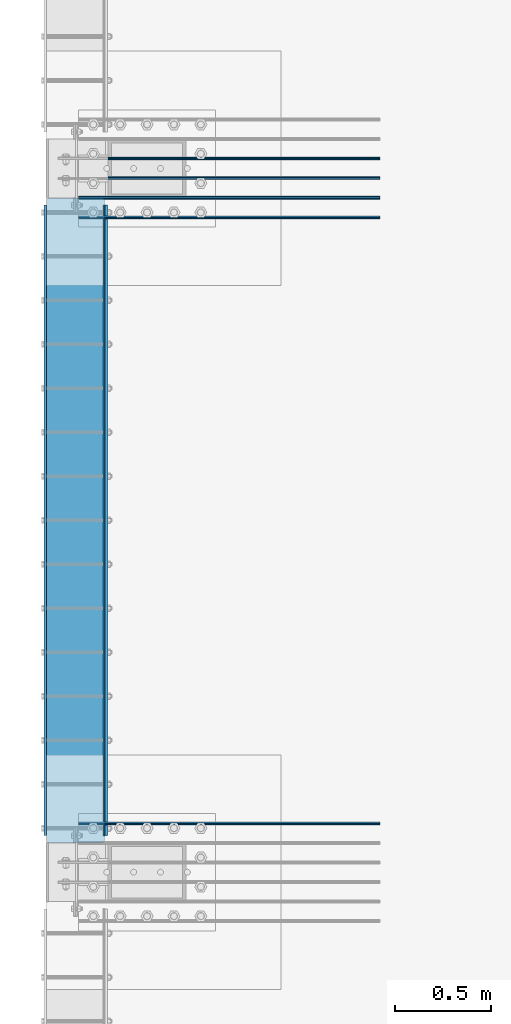
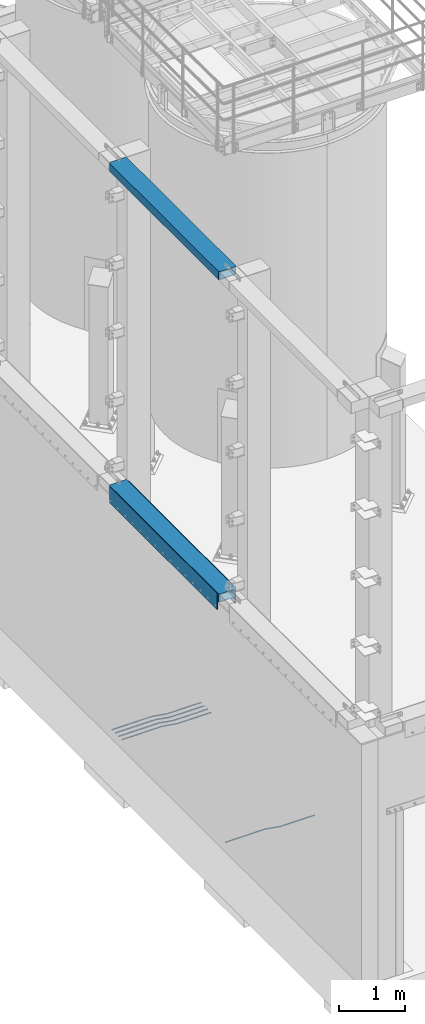
# One storey, part 911 of 1876: 10 beams, 5 elements without a shape of their own.
"""IFC2X3 building model written with IfcOpenShell, lengths in millimetres."""

from ifc_helpers import new_model, si_unit, frame, origin_with_axes, place, context, subcontext, project, spatial, faceted_brep, material, type_object, element, aggregate, save


model = new_model("IFC2X3")

# Units and contexts
model_context = context("Model", 3, precision=1e-05, world=origin_with_axes())
body_context = subcontext(model_context, "Body", "Model", "MODEL_VIEW")
ifc_project = project(units=[si_unit("LENGTHUNIT", "METRE", prefix="MILLI"), si_unit("AREAUNIT", "SQUARE_METRE"), si_unit("VOLUMEUNIT", "CUBIC_METRE"), si_unit("MASSUNIT", "GRAM", prefix="KILO"), si_unit("TIMEUNIT", "SECOND"), si_unit("PLANEANGLEUNIT", "RADIAN"), si_unit("SOLIDANGLEUNIT", "STERADIAN"), si_unit("THERMODYNAMICTEMPERATUREUNIT", "DEGREE_CELSIUS"), si_unit("LUMINOUSINTENSITYUNIT", "LUMEN")], contexts=[model_context])

# Site, building, storey
site_placement = place(None, origin_with_axes())
site = spatial("IfcSite", under=ifc_project, at=site_placement, CompositionType="ELEMENT")
building_placement = place(site_placement, origin_with_axes())
building = spatial("IfcBuilding", under=site, at=building_placement, Name="Undefined", CompositionType="ELEMENT")
storey_placement = place(building_placement, origin_with_axes())
storey = spatial("IfcBuildingStorey", under=building, at=storey_placement, Name="Undefined", CompositionType="ELEMENT", Elevation=0.0)

# Assembly, beam
assembly_1_placement = place(storey_placement, origin_with_axes())
assembly_1 = element("IfcElementAssembly", 1, at=assembly_1_placement, inside=storey, Name="BEAM", AssemblyPlace="NOTDEFINED", PredefinedType="RIGID_FRAME")
ifc_material_1 = material()
beam_type_1 = type_object("IfcBeamType", Name="HSS12X6X1/2", PredefinedType="NOTDEFINED")
beam_1_placement = place(assembly_1_placement, frame((-139.7, -21590.0, 10591.8), z_axis=(-1.0, 0.0, 0.0), x_axis=(0.0, 1.0, 0.0)))
beam_1 = element("IfcBeam", 2, at=beam_1_placement, type_object=beam_type_1, material=ifc_material_1, Name="BEAM", ObjectType="HSS12X6X1/2", context=body_context, shape_type="Brep", body=[
    faceted_brep([(0.0, -63.5, -139.7), (0.0, -76.2000000000007, -139.699999999812), (0.0, -76.2000000000007, 139.700000000026), (0.0, -63.5, 139.7), (0.0, 76.2000000000007, 139.700000000026), (0.0, 63.5, 139.7), (12.6999999999734, -76.2000000000007, 152.4), (12.6999999999734, 76.2000000000007, 152.4), (0.0, 76.2000000000007, -139.699999999812), (0.0, 63.5, -139.7), (12.7000000000025, -76.2000000000007, -152.4), (12.7000000000025, 76.2000000000007, -152.4), (3340.1, 76.2000000000007, -152.4), (3340.1, -76.2000000000007, -152.4), (3352.8, -63.5, -139.7), (3352.8, 63.5, -139.7), (3352.8, 76.2000000000007, -139.7), (3352.8, -76.2000000000007, -139.7), (3352.8, -76.2000000000007, 139.7), (3340.1, -76.2000000000007, 152.4), (3340.1, 76.2000000000007, 152.4), (3352.8, 76.2000000000007, 139.7), (3352.8, 63.5, 139.7), (3352.8, -63.5, 139.7)], [[[0, 1, 2, 3]], [[4, 5, 3, 2, 6, 7]], [[8, 9, 5, 4]], [[10, 11, 12, 13]], [[0, 9, 8, 11, 10, 1]], [[9, 0, 14, 15]], [[12, 16, 15, 14, 17, 13]], [[6, 2, 1, 10, 13, 17, 18, 19]], [[7, 6, 19, 20]], [[16, 12, 11, 8, 4, 7, 20, 21]], [[15, 16, 21, 22]], [[5, 9, 15, 22]], [[3, 5, 22, 23]], [[0, 3, 23, 14]], [[17, 14, 23, 18]], [[22, 21, 20, 19, 18, 23]]]),
])
aggregate(assembly_1, [beam_1])

assembly_2_placement = place(storey_placement, origin_with_axes())
assembly_2 = element("IfcElementAssembly", 3, at=assembly_2_placement, inside=storey, Name="BEAM", AssemblyPlace="NOTDEFINED", PredefinedType="RIGID_FRAME")
beam_2_placement = place(assembly_2_placement, frame((-139.7, -21590.0, 4597.4), z_axis=(-1.0, 0.0, 0.0), x_axis=(0.0, 1.0, 0.0)))
beam_2 = element("IfcBeam", 4, at=beam_2_placement, type_object=beam_type_1, material=ifc_material_1, Name="BEAM", ObjectType="HSS12X6X1/2", context=body_context, shape_type="Brep", body=[
    faceted_brep([(3340.10010842724, 76.1999999999998, -152.4), (3340.10010842724, -76.1999999999998, -152.4), (12.6998385541701, -76.2000000000007, -152.4), (12.6998385541701, 76.2000000000007, -152.4), (0.0, -63.5, -139.7), (0.0, 63.5, -139.7), (0.0, 76.2000000000007, -139.699999999812), (0.0, -76.2000000000007, -139.699999999812), (3352.8, -63.5, -139.7), (3352.8, 63.5, -139.7), (3352.8, 76.2000000000007, -139.7), (3352.8, -76.2000000000007, -139.7), (3352.8, -76.2000000000007, 139.7), (3340.1, -76.2000000000007, 152.4), (12.6999999999734, -76.2000000000007, 152.4), (0.0, -76.2000000000007, 139.700000000026), (0.0, -63.5, 139.7), (0.0, 63.5, 139.7), (3352.8, 63.5, 139.7), (3352.8, -63.5, 139.7), (3352.8, 76.2000000000007, 139.7), (3340.1, 76.2000000000007, 152.4), (0.0, 76.2000000000007, 139.700000000026), (12.6999999999734, 76.2000000000007, 152.4)], [[[0, 1, 2, 3]], [[4, 5, 6, 3, 2, 7]], [[5, 4, 8, 9]], [[0, 10, 9, 8, 11, 1]], [[7, 2, 1, 11, 12, 13, 14, 15]], [[4, 7, 15, 16]], [[16, 17, 18, 19]], [[4, 16, 19, 8]], [[11, 8, 19, 12]], [[18, 20, 21, 13, 12, 19]], [[9, 10, 20, 18]], [[17, 5, 9, 18]], [[6, 5, 17, 22]], [[21, 20, 10, 0, 3, 6, 22, 23]], [[23, 14, 13, 21]], [[22, 17, 16, 15, 14, 23]]]),
])

# Assembly, beams
assembly_3_placement = place(storey_placement, origin_with_axes())
assembly_3 = element("IfcElementAssembly", 5, at=assembly_3_placement, inside=storey, Name="PLATE", AssemblyPlace="NOTDEFINED", PredefinedType="RIGID_FRAME")
ifc_material_2 = material(Name="STEEL/A36")
beam_type_2 = type_object("IfcBeamType", PredefinedType="NOTDEFINED")
beam_3_placement = place(assembly_3_placement, frame((8.73150000000262, -18275.3, 4432.3), z_axis=(0.0, 0.0, 1.0), x_axis=(0.0, -1.0, 0.0)))
beam_3 = element("IfcBeam", 6, at=beam_3_placement, type_object=beam_type_2, material=ifc_material_2, Name="PLATE", context=body_context, shape_type="Brep", body=[
    faceted_brep([(0.0, 3.969, -38.1000000000004), (0.0, 3.969, 38.1000000000004), (3276.6, 3.96900000000096, 38.1000000000004), (3276.6, 3.96900000000096, -38.1000000000004), (0.0, -3.969, 38.1000000000004), (3276.6, -3.96900000000096, 38.1000000000004), (0.0, -3.969, -38.1000000000004), (3276.6, -3.96900000000096, -38.1000000000004)], [[[0, 1, 2, 3]], [[1, 4, 5, 2]], [[4, 6, 7, 5]], [[6, 0, 3, 7]], [[5, 7, 3, 2]], [[6, 4, 1, 0]]]),
])
beam_type_3 = type_object("IfcBeamType", PredefinedType="NOTDEFINED")
beam_4_placement = place(assembly_3_placement, frame((19.0500000000011, -18275.3, 4521.2), z_axis=(0.0, 0.0, 1.0), x_axis=(0.0, -1.0, 0.0)))
beam_4 = element("IfcBeam", 7, at=beam_4_placement, type_object=beam_type_3, material=ifc_material_2, Name="PLATE", context=body_context, shape_type="Brep", body=[
    faceted_brep([(0.0, 6.35000000000002, -152.4), (0.0, 6.35000000000002, 152.4), (3276.6, 6.35000000000002, 152.4), (3276.6, 6.35000000000002, -152.4), (0.0, -6.35000000000002, 152.4), (3276.6, -6.35000000000002, 152.4), (0.0, -6.35000000000002, -152.4), (3276.6, -6.35000000000002, -152.4)], [[[0, 1, 2, 3]], [[1, 4, 5, 2]], [[4, 6, 7, 5]], [[6, 0, 3, 7]], [[5, 7, 3, 2]], [[6, 4, 1, 0]]]),
])
aggregate(assembly_3, [beam_3, beam_4])

# Beam
beam_5_placement = place(assembly_2_placement, frame((-298.449999999996, -18275.3, 4521.2), z_axis=(0.0, 0.0, 1.0), x_axis=(0.0, -1.0, 0.0)))
beam_5 = element("IfcBeam", 8, at=beam_5_placement, type_object=beam_type_3, material=ifc_material_2, Name="PLATE", context=body_context, shape_type="Brep", body=[
    faceted_brep([(0.0, 6.35000000000002, -152.4), (0.0, 6.35000000000002, 152.4), (3276.6, 6.35000000000002, 152.4), (3276.6, 6.35000000000002, -152.4), (0.0, -6.35000000000002, 152.4), (3276.6, -6.35000000000002, 152.4), (0.0, -6.35000000000002, -152.4), (3276.6, -6.35000000000002, -152.4)], [[[0, 1, 2, 3]], [[1, 4, 5, 2]], [[4, 6, 7, 5]], [[6, 0, 3, 7]], [[5, 7, 3, 2]], [[6, 4, 1, 0]]]),
])

aggregate(assembly_2, [beam_5, beam_2])

# Assembly, beam
assembly_4_placement = place(storey_placement, origin_with_axes())
assembly_4 = element("IfcElementAssembly", 9, at=assembly_4_placement, inside=storey, Name="PLATE", AssemblyPlace="NOTDEFINED", PredefinedType="RIGID_FRAME")
ifc_material_3 = material(Name="STEEL/A706-GR.60")
beam_type_4 = type_object("IfcBeamType", Name="5 REBAR", PredefinedType="NOTDEFINED")
beam_6_placement = place(assembly_4_placement, frame((-123.825012207033, -21488.4, -58.7374999999993), z_axis=(0.0, 1.0, 0.0), x_axis=(1.0, 0.0, 0.0)))
beam_6 = element("IfcBeam", 10, at=beam_6_placement, type_object=beam_type_4, material=ifc_material_3, Name="REBAR", ObjectType="5 REBAR", context=body_context, shape_type="Brep", body=[
    faceted_brep([(0.0, -7.9375, 0.0), (0.0, -5.61266007566822, -5.61266007566883), (710.034986674476, -5.61266007566822, -5.61266007566883), (710.034986674476, -7.9375, 0.0), (0.0, 0.0, -7.9375), (710.034986674476, 0.0, -7.9375), (0.0, 5.61266007566822, -5.61266007566883), (710.034986674476, 5.61266007566822, -5.61266007566883), (0.0, 7.9375, 0.0), (710.034986674476, 7.9375, 0.0), (0.0, 5.61266007566822, 5.61266007566883), (710.034986674476, 5.61266007566822, 5.61266007566883), (0.0, 0.0, 7.9375), (710.034986674476, 0.0, 7.9375), (0.0, -5.61266007566822, 5.61266007566883), (710.034986674476, -5.61266007566822, 5.61266007566883), (711.670256270764, -5.61266007566822, -5.61266007566883), (711.865037739587, -7.9375, 0.0), (711.200012207031, 0.0, -7.9375), (710.729768143299, 5.61266007566822, -5.61266007566883), (710.534986674476, 7.9375, 0.0), (710.729768143299, 5.61266007566822, 5.61266007566883), (711.200012207031, 0.0, 7.9375), (711.670256270764, -5.61266007566822, 5.61266007566883), (713.282728188834, -5.34055537895146, -5.61266007566883), (713.669575632193, -7.63298416286913, 0.0), (712.34879584451, 0.193857281957023, -7.9375), (711.414863500185, 5.72826994286551, -5.61266007566883), (711.028016056827, 8.02069872678318, 0.0), (711.414863500185, 5.72826994286551, 5.61266007566883), (712.34879584451, 0.193857281957023, 7.9375), (713.282728188834, -5.34055537895146, 5.61266007566883), (964.985099878721, 37.1342292941951, -5.61266007566883), (965.371947322079, 34.8418005102774, 0.0), (964.051167534397, 42.6686419551035, -7.9375), (963.117235190072, 48.203054616012, -5.61266007566883), (962.730387746714, 50.4954833999297, 0.0), (963.117235190072, 48.203054616012, 5.61266007566883), (964.051167534397, 42.6686419551035, 7.9375), (964.985099878721, 37.1342292941951, 5.61266007566883), (965.670195235607, 37.2498391613923, -5.61266007566883), (965.864976704431, 34.9249992370606, 0.0), (965.199951171875, 42.8624992370605, -7.9375), (964.729707108143, 48.4751593127287, -5.61266007566883), (964.534925639319, 50.7999992370605, 0.0), (964.729707108143, 48.4751593127287, 5.61266007566883), (965.199951171875, 42.8624992370605, 7.9375), (965.670195235607, 37.2498391613923, 5.61266007566883), (966.36497670443, 37.2498391613923, -5.61266007566883), (966.36497670443, 34.9249992370605, 0.0), (966.36497670443, 42.8624992370605, -7.9375), (966.36497670443, 48.4751593127288, -5.61266007566883), (966.36497670443, 50.7999992370605, 0.0), (966.36497670443, 48.4751593127288, 5.61266007566883), (966.36497670443, 42.8624992370605, 7.9375), (966.36497670443, 37.2498391613923, 5.61266007566883), (1566.86254882812, 37.2498391613923, -5.61266007566883), (1566.86254882812, 34.9249992370605, 0.0), (1566.86254882812, 42.8624992370605, -7.9375), (1566.86254882812, 48.4751593127288, -5.61266007566883), (1566.86254882812, 50.7999992370605, 0.0), (1566.86254882812, 48.4751593127288, 5.61266007566883), (1566.86254882812, 42.8624992370605, 7.9375), (1566.86254882812, 37.2498391613923, 5.61266007566883)], [[[0, 1, 2, 3]], [[1, 4, 5, 2]], [[4, 6, 7, 5]], [[6, 8, 9, 7]], [[8, 10, 11, 9]], [[10, 12, 13, 11]], [[12, 14, 15, 13]], [[14, 0, 3, 15]], [[14, 12, 10, 8, 6, 4, 1, 0]], [[3, 2, 16, 17]], [[2, 5, 18, 16]], [[5, 7, 19, 18]], [[7, 9, 20, 19]], [[9, 11, 21, 20]], [[11, 13, 22, 21]], [[13, 15, 23, 22]], [[15, 3, 17, 23]], [[17, 16, 24, 25]], [[16, 18, 26, 24]], [[18, 19, 27, 26]], [[19, 20, 28, 27]], [[20, 21, 29, 28]], [[21, 22, 30, 29]], [[22, 23, 31, 30]], [[23, 17, 25, 31]], [[25, 24, 32, 33]], [[24, 26, 34, 32]], [[26, 27, 35, 34]], [[27, 28, 36, 35]], [[28, 29, 37, 36]], [[29, 30, 38, 37]], [[30, 31, 39, 38]], [[31, 25, 33, 39]], [[33, 32, 40, 41]], [[32, 34, 42, 40]], [[34, 35, 43, 42]], [[35, 36, 44, 43]], [[36, 37, 45, 44]], [[37, 38, 46, 45]], [[38, 39, 47, 46]], [[39, 33, 41, 47]], [[41, 40, 48, 49]], [[40, 42, 50, 48]], [[42, 43, 51, 50]], [[43, 44, 52, 51]], [[44, 45, 53, 52]], [[45, 46, 54, 53]], [[46, 47, 55, 54]], [[47, 41, 49, 55]], [[49, 48, 56, 57]], [[48, 50, 58, 56]], [[50, 51, 59, 58]], [[51, 52, 60, 59]], [[52, 53, 61, 60]], [[53, 54, 62, 61]], [[54, 55, 63, 62]], [[55, 49, 57, 63]], [[58, 59, 60, 61, 62, 63, 57, 56]]]),
])
aggregate(assembly_4, [beam_6])

# Assembly, beams
assembly_5_placement = place(storey_placement, origin_with_axes())
assembly_5 = element("IfcElementAssembly", 11, at=assembly_5_placement, inside=storey, Name="PLATE", AssemblyPlace="NOTDEFINED", PredefinedType="RIGID_FRAME")
beam_7_placement = place(assembly_5_placement, frame((-123.825012207033, -18237.199983724, -58.7375000000029), z_axis=(0.0, 1.0, 0.0), x_axis=(1.0, 0.0, 0.0)))
beam_7 = element("IfcBeam", 12, at=beam_7_placement, type_object=beam_type_4, material=ifc_material_3, Name="REBAR", ObjectType="5 REBAR", context=body_context, shape_type="Brep", body=[
    faceted_brep([(0.0, -7.9375, 0.0), (0.0, -5.61266007566822, -5.61266007566883), (710.034986674476, -5.61266007566822, -5.61266007566883), (710.034986674476, -7.9375, 0.0), (0.0, 0.0, -7.9375), (710.034986674476, 0.0, -7.9375), (0.0, 5.61266007566822, -5.61266007566883), (710.034986674476, 5.61266007566822, -5.61266007566883), (0.0, 7.9375, 0.0), (710.034986674476, 7.9375, 0.0), (0.0, 5.61266007566822, 5.61266007566883), (710.034986674476, 5.61266007566822, 5.61266007566883), (0.0, 0.0, 7.9375), (710.034986674476, 0.0, 7.9375), (0.0, -5.61266007566822, 5.61266007566883), (710.034986674476, -5.61266007566822, 5.61266007566883), (711.670256270764, -5.61266007566822, -5.61266007566883), (711.865037739587, -7.9375, 0.0), (711.200012207031, 0.0, -7.9375), (710.729768143299, 5.61266007566822, -5.61266007566883), (710.534986674476, 7.9375, 0.0), (710.729768143299, 5.61266007566822, 5.61266007566883), (711.200012207031, 0.0, 7.9375), (711.670256270764, -5.61266007566822, 5.61266007566883), (713.282728188834, -5.34055537895146, -5.61266007566883), (713.669575632193, -7.63298416286913, 0.0), (712.34879584451, 0.193857281957023, -7.9375), (711.414863500185, 5.72826994286551, -5.61266007566883), (711.028016056827, 8.02069872678318, 0.0), (711.414863500185, 5.72826994286551, 5.61266007566883), (712.34879584451, 0.193857281957023, 7.9375), (713.282728188834, -5.34055537895146, 5.61266007566883), (964.985099878721, 37.1342292941951, -5.61266007566883), (965.371947322079, 34.8418005102774, 0.0), (964.051167534397, 42.6686419551035, -7.9375), (963.117235190072, 48.203054616012, -5.61266007566883), (962.730387746714, 50.4954833999297, 0.0), (963.117235190072, 48.203054616012, 5.61266007566883), (964.051167534397, 42.6686419551035, 7.9375), (964.985099878721, 37.1342292941951, 5.61266007566883), (965.670195235607, 37.2498391613923, -5.61266007566883), (965.864976704431, 34.9249992370606, 0.0), (965.199951171875, 42.8624992370605, -7.9375), (964.729707108143, 48.4751593127287, -5.61266007566883), (964.534925639319, 50.7999992370605, 0.0), (964.729707108143, 48.4751593127287, 5.61266007566883), (965.199951171875, 42.8624992370605, 7.9375), (965.670195235607, 37.2498391613923, 5.61266007566883), (966.36497670443, 37.2498391613923, -5.61266007566883), (966.36497670443, 34.9249992370605, 0.0), (966.36497670443, 42.8624992370605, -7.9375), (966.36497670443, 48.4751593127288, -5.61266007566883), (966.36497670443, 50.7999992370605, 0.0), (966.36497670443, 48.4751593127288, 5.61266007566883), (966.36497670443, 42.8624992370605, 7.9375), (966.36497670443, 37.2498391613923, 5.61266007566883), (1566.86254882812, 37.2498391613923, -5.61266007566883), (1566.86254882812, 34.9249992370605, 0.0), (1566.86254882812, 42.8624992370605, -7.9375), (1566.86254882812, 48.4751593127288, -5.61266007566883), (1566.86254882812, 50.7999992370605, 0.0), (1566.86254882812, 48.4751593127288, 5.61266007566883), (1566.86254882812, 42.8624992370605, 7.9375), (1566.86254882812, 37.2498391613923, 5.61266007566883)], [[[0, 1, 2, 3]], [[1, 4, 5, 2]], [[4, 6, 7, 5]], [[6, 8, 9, 7]], [[8, 10, 11, 9]], [[10, 12, 13, 11]], [[12, 14, 15, 13]], [[14, 0, 3, 15]], [[14, 12, 10, 8, 6, 4, 1, 0]], [[3, 2, 16, 17]], [[2, 5, 18, 16]], [[5, 7, 19, 18]], [[7, 9, 20, 19]], [[9, 11, 21, 20]], [[11, 13, 22, 21]], [[13, 15, 23, 22]], [[15, 3, 17, 23]], [[17, 16, 24, 25]], [[16, 18, 26, 24]], [[18, 19, 27, 26]], [[19, 20, 28, 27]], [[20, 21, 29, 28]], [[21, 22, 30, 29]], [[22, 23, 31, 30]], [[23, 17, 25, 31]], [[25, 24, 32, 33]], [[24, 26, 34, 32]], [[26, 27, 35, 34]], [[27, 28, 36, 35]], [[28, 29, 37, 36]], [[29, 30, 38, 37]], [[30, 31, 39, 38]], [[31, 25, 33, 39]], [[33, 32, 40, 41]], [[32, 34, 42, 40]], [[34, 35, 43, 42]], [[35, 36, 44, 43]], [[36, 37, 45, 44]], [[37, 38, 46, 45]], [[38, 39, 47, 46]], [[39, 33, 41, 47]], [[41, 40, 48, 49]], [[40, 42, 50, 48]], [[42, 43, 51, 50]], [[43, 44, 52, 51]], [[44, 45, 53, 52]], [[45, 46, 54, 53]], [[46, 47, 55, 54]], [[47, 41, 49, 55]], [[49, 48, 56, 57]], [[48, 50, 58, 56]], [[50, 51, 59, 58]], [[51, 52, 60, 59]], [[52, 53, 61, 60]], [[53, 54, 62, 61]], [[54, 55, 63, 62]], [[55, 49, 57, 63]], [[58, 59, 60, 61, 62, 63, 57, 56]]]),
])
beam_8_placement = place(assembly_5_placement, frame((-123.825012207033, -18135.599983724, -58.7375000000029), z_axis=(0.0, 1.0, 0.0), x_axis=(1.0, 0.0, 0.0)))
beam_8 = element("IfcBeam", 13, at=beam_8_placement, type_object=beam_type_4, material=ifc_material_3, Name="REBAR", ObjectType="5 REBAR", context=body_context, shape_type="Brep", body=[
    faceted_brep([(0.0, -7.9375, 0.0), (0.0, -5.61266007566822, -5.61266007566883), (710.034986674476, -5.61266007566822, -5.61266007566883), (710.034986674476, -7.9375, 0.0), (0.0, 0.0, -7.9375), (710.034986674476, 0.0, -7.9375), (0.0, 5.61266007566822, -5.61266007566883), (710.034986674476, 5.61266007566822, -5.61266007566883), (0.0, 7.9375, 0.0), (710.034986674476, 7.9375, 0.0), (0.0, 5.61266007566822, 5.61266007566883), (710.034986674476, 5.61266007566822, 5.61266007566883), (0.0, 0.0, 7.9375), (710.034986674476, 0.0, 7.9375), (0.0, -5.61266007566822, 5.61266007566883), (710.034986674476, -5.61266007566822, 5.61266007566883), (711.670256270764, -5.61266007566822, -5.61266007566883), (711.865037739587, -7.9375, 0.0), (711.200012207031, 0.0, -7.9375), (710.729768143299, 5.61266007566822, -5.61266007566883), (710.534986674476, 7.9375, 0.0), (710.729768143299, 5.61266007566822, 5.61266007566883), (711.200012207031, 0.0, 7.9375), (711.670256270764, -5.61266007566822, 5.61266007566883), (713.282728188834, -5.34055537895146, -5.61266007566883), (713.669575632193, -7.63298416286913, 0.0), (712.34879584451, 0.193857281957023, -7.9375), (711.414863500185, 5.72826994286551, -5.61266007566883), (711.028016056827, 8.02069872678318, 0.0), (711.414863500185, 5.72826994286551, 5.61266007566883), (712.34879584451, 0.193857281957023, 7.9375), (713.282728188834, -5.34055537895146, 5.61266007566883), (964.985099878721, 37.1342292941951, -5.61266007566883), (965.371947322079, 34.8418005102774, 0.0), (964.051167534397, 42.6686419551035, -7.9375), (963.117235190072, 48.203054616012, -5.61266007566883), (962.730387746714, 50.4954833999297, 0.0), (963.117235190072, 48.203054616012, 5.61266007566883), (964.051167534397, 42.6686419551035, 7.9375), (964.985099878721, 37.1342292941951, 5.61266007566883), (965.670195235607, 37.2498391613923, -5.61266007566883), (965.864976704431, 34.9249992370606, 0.0), (965.199951171875, 42.8624992370605, -7.9375), (964.729707108143, 48.4751593127287, -5.61266007566883), (964.534925639319, 50.7999992370605, 0.0), (964.729707108143, 48.4751593127287, 5.61266007566883), (965.199951171875, 42.8624992370605, 7.9375), (965.670195235607, 37.2498391613923, 5.61266007566883), (966.36497670443, 37.2498391613923, -5.61266007566883), (966.36497670443, 34.9249992370605, 0.0), (966.36497670443, 42.8624992370605, -7.9375), (966.36497670443, 48.4751593127288, -5.61266007566883), (966.36497670443, 50.7999992370605, 0.0), (966.36497670443, 48.4751593127288, 5.61266007566883), (966.36497670443, 42.8624992370605, 7.9375), (966.36497670443, 37.2498391613923, 5.61266007566883), (1566.86254882812, 37.2498391613923, -5.61266007566883), (1566.86254882812, 34.9249992370605, 0.0), (1566.86254882812, 42.8624992370605, -7.9375), (1566.86254882812, 48.4751593127288, -5.61266007566883), (1566.86254882812, 50.7999992370605, 0.0), (1566.86254882812, 48.4751593127288, 5.61266007566883), (1566.86254882812, 42.8624992370605, 7.9375), (1566.86254882812, 37.2498391613923, 5.61266007566883)], [[[0, 1, 2, 3]], [[1, 4, 5, 2]], [[4, 6, 7, 5]], [[6, 8, 9, 7]], [[8, 10, 11, 9]], [[10, 12, 13, 11]], [[12, 14, 15, 13]], [[14, 0, 3, 15]], [[14, 12, 10, 8, 6, 4, 1, 0]], [[3, 2, 16, 17]], [[2, 5, 18, 16]], [[5, 7, 19, 18]], [[7, 9, 20, 19]], [[9, 11, 21, 20]], [[11, 13, 22, 21]], [[13, 15, 23, 22]], [[15, 3, 17, 23]], [[17, 16, 24, 25]], [[16, 18, 26, 24]], [[18, 19, 27, 26]], [[19, 20, 28, 27]], [[20, 21, 29, 28]], [[21, 22, 30, 29]], [[22, 23, 31, 30]], [[23, 17, 25, 31]], [[25, 24, 32, 33]], [[24, 26, 34, 32]], [[26, 27, 35, 34]], [[27, 28, 36, 35]], [[28, 29, 37, 36]], [[29, 30, 38, 37]], [[30, 31, 39, 38]], [[31, 25, 33, 39]], [[33, 32, 40, 41]], [[32, 34, 42, 40]], [[34, 35, 43, 42]], [[35, 36, 44, 43]], [[36, 37, 45, 44]], [[37, 38, 46, 45]], [[38, 39, 47, 46]], [[39, 33, 41, 47]], [[41, 40, 48, 49]], [[40, 42, 50, 48]], [[42, 43, 51, 50]], [[43, 44, 52, 51]], [[44, 45, 53, 52]], [[45, 46, 54, 53]], [[46, 47, 55, 54]], [[47, 41, 49, 55]], [[49, 48, 56, 57]], [[48, 50, 58, 56]], [[50, 51, 59, 58]], [[51, 52, 60, 59]], [[52, 53, 61, 60]], [[53, 54, 62, 61]], [[54, 55, 63, 62]], [[55, 49, 57, 63]], [[58, 59, 60, 61, 62, 63, 57, 56]]]),
])
beam_9_placement = place(assembly_5_placement, frame((-123.825012207033, -18033.999991862, -58.7375000000029), z_axis=(0.0, 1.0, 0.0), x_axis=(1.0, 0.0, 0.0)))
beam_9 = element("IfcBeam", 14, at=beam_9_placement, type_object=beam_type_4, material=ifc_material_3, Name="REBAR", ObjectType="5 REBAR", context=body_context, shape_type="Brep", body=[
    faceted_brep([(0.0, -7.9375, 0.0), (0.0, -5.61266007566822, -5.61266007566883), (710.034986674476, -5.61266007566822, -5.61266007566883), (710.034986674476, -7.9375, 0.0), (0.0, 0.0, -7.9375), (710.034986674476, 0.0, -7.9375), (0.0, 5.61266007566822, -5.61266007566883), (710.034986674476, 5.61266007566822, -5.61266007566883), (0.0, 7.9375, 0.0), (710.034986674476, 7.9375, 0.0), (0.0, 5.61266007566822, 5.61266007566883), (710.034986674476, 5.61266007566822, 5.61266007566883), (0.0, 0.0, 7.9375), (710.034986674476, 0.0, 7.9375), (0.0, -5.61266007566822, 5.61266007566883), (710.034986674476, -5.61266007566822, 5.61266007566883), (711.670256270764, -5.61266007566822, -5.61266007566883), (711.865037739587, -7.9375, 0.0), (711.200012207031, 0.0, -7.9375), (710.729768143299, 5.61266007566822, -5.61266007566883), (710.534986674476, 7.9375, 0.0), (710.729768143299, 5.61266007566822, 5.61266007566883), (711.200012207031, 0.0, 7.9375), (711.670256270764, -5.61266007566822, 5.61266007566883), (713.282728188834, -5.34055537895146, -5.61266007566883), (713.669575632193, -7.63298416286913, 0.0), (712.34879584451, 0.193857281957023, -7.9375), (711.414863500185, 5.72826994286551, -5.61266007566883), (711.028016056827, 8.02069872678318, 0.0), (711.414863500185, 5.72826994286551, 5.61266007566883), (712.34879584451, 0.193857281957023, 7.9375), (713.282728188834, -5.34055537895146, 5.61266007566883), (964.985099878721, 37.1342292941951, -5.61266007566883), (965.371947322079, 34.8418005102774, 0.0), (964.051167534397, 42.6686419551035, -7.9375), (963.117235190072, 48.203054616012, -5.61266007566883), (962.730387746714, 50.4954833999297, 0.0), (963.117235190072, 48.203054616012, 5.61266007566883), (964.051167534397, 42.6686419551035, 7.9375), (964.985099878721, 37.1342292941951, 5.61266007566883), (965.670195235607, 37.2498391613923, -5.61266007566883), (965.864976704431, 34.9249992370606, 0.0), (965.199951171875, 42.8624992370605, -7.9375), (964.729707108143, 48.4751593127287, -5.61266007566883), (964.534925639319, 50.7999992370605, 0.0), (964.729707108143, 48.4751593127287, 5.61266007566883), (965.199951171875, 42.8624992370605, 7.9375), (965.670195235607, 37.2498391613923, 5.61266007566883), (966.36497670443, 37.2498391613923, -5.61266007566883), (966.36497670443, 34.9249992370605, 0.0), (966.36497670443, 42.8624992370605, -7.9375), (966.36497670443, 48.4751593127288, -5.61266007566883), (966.36497670443, 50.7999992370605, 0.0), (966.36497670443, 48.4751593127288, 5.61266007566883), (966.36497670443, 42.8624992370605, 7.9375), (966.36497670443, 37.2498391613923, 5.61266007566883), (1566.86254882812, 37.2498391613923, -5.61266007566883), (1566.86254882812, 34.9249992370605, 0.0), (1566.86254882812, 42.8624992370605, -7.9375), (1566.86254882812, 48.4751593127288, -5.61266007566883), (1566.86254882812, 50.7999992370605, 0.0), (1566.86254882812, 48.4751593127288, 5.61266007566883), (1566.86254882812, 42.8624992370605, 7.9375), (1566.86254882812, 37.2498391613923, 5.61266007566883)], [[[0, 1, 2, 3]], [[1, 4, 5, 2]], [[4, 6, 7, 5]], [[6, 8, 9, 7]], [[8, 10, 11, 9]], [[10, 12, 13, 11]], [[12, 14, 15, 13]], [[14, 0, 3, 15]], [[14, 12, 10, 8, 6, 4, 1, 0]], [[3, 2, 16, 17]], [[2, 5, 18, 16]], [[5, 7, 19, 18]], [[7, 9, 20, 19]], [[9, 11, 21, 20]], [[11, 13, 22, 21]], [[13, 15, 23, 22]], [[15, 3, 17, 23]], [[17, 16, 24, 25]], [[16, 18, 26, 24]], [[18, 19, 27, 26]], [[19, 20, 28, 27]], [[20, 21, 29, 28]], [[21, 22, 30, 29]], [[22, 23, 31, 30]], [[23, 17, 25, 31]], [[25, 24, 32, 33]], [[24, 26, 34, 32]], [[26, 27, 35, 34]], [[27, 28, 36, 35]], [[28, 29, 37, 36]], [[29, 30, 38, 37]], [[30, 31, 39, 38]], [[31, 25, 33, 39]], [[33, 32, 40, 41]], [[32, 34, 42, 40]], [[34, 35, 43, 42]], [[35, 36, 44, 43]], [[36, 37, 45, 44]], [[37, 38, 46, 45]], [[38, 39, 47, 46]], [[39, 33, 41, 47]], [[41, 40, 48, 49]], [[40, 42, 50, 48]], [[42, 43, 51, 50]], [[43, 44, 52, 51]], [[44, 45, 53, 52]], [[45, 46, 54, 53]], [[46, 47, 55, 54]], [[47, 41, 49, 55]], [[49, 48, 56, 57]], [[48, 50, 58, 56]], [[50, 51, 59, 58]], [[51, 52, 60, 59]], [[52, 53, 61, 60]], [[53, 54, 62, 61]], [[54, 55, 63, 62]], [[55, 49, 57, 63]], [[58, 59, 60, 61, 62, 63, 57, 56]]]),
])
beam_10_placement = place(assembly_5_placement, frame((-123.825012207033, -18338.799983724, -58.7375000000029), z_axis=(0.0, 1.0, 0.0), x_axis=(1.0, 0.0, 0.0)))
beam_10 = element("IfcBeam", 15, at=beam_10_placement, type_object=beam_type_4, material=ifc_material_3, Name="REBAR", ObjectType="5 REBAR", context=body_context, shape_type="Brep", body=[
    faceted_brep([(0.0, -7.9375, 0.0), (0.0, -5.61266007566822, -5.61266007566883), (710.034986674476, -5.61266007566822, -5.61266007566883), (710.034986674476, -7.9375, 0.0), (0.0, 0.0, -7.9375), (710.034986674476, 0.0, -7.9375), (0.0, 5.61266007566822, -5.61266007566883), (710.034986674476, 5.61266007566822, -5.61266007566883), (0.0, 7.9375, 0.0), (710.034986674476, 7.9375, 0.0), (0.0, 5.61266007566822, 5.61266007566883), (710.034986674476, 5.61266007566822, 5.61266007566883), (0.0, 0.0, 7.9375), (710.034986674476, 0.0, 7.9375), (0.0, -5.61266007566822, 5.61266007566883), (710.034986674476, -5.61266007566822, 5.61266007566883), (711.670256270764, -5.61266007566822, -5.61266007566883), (711.865037739587, -7.9375, 0.0), (711.200012207031, 0.0, -7.9375), (710.729768143299, 5.61266007566822, -5.61266007566883), (710.534986674476, 7.9375, 0.0), (710.729768143299, 5.61266007566822, 5.61266007566883), (711.200012207031, 0.0, 7.9375), (711.670256270764, -5.61266007566822, 5.61266007566883), (713.282728188834, -5.34055537895146, -5.61266007566883), (713.669575632193, -7.63298416286913, 0.0), (712.34879584451, 0.193857281957023, -7.9375), (711.414863500185, 5.72826994286551, -5.61266007566883), (711.028016056827, 8.02069872678318, 0.0), (711.414863500185, 5.72826994286551, 5.61266007566883), (712.34879584451, 0.193857281957023, 7.9375), (713.282728188834, -5.34055537895146, 5.61266007566883), (964.985099878721, 37.1342292941951, -5.61266007566883), (965.371947322079, 34.8418005102774, 0.0), (964.051167534397, 42.6686419551035, -7.9375), (963.117235190072, 48.203054616012, -5.61266007566883), (962.730387746714, 50.4954833999297, 0.0), (963.117235190072, 48.203054616012, 5.61266007566883), (964.051167534397, 42.6686419551035, 7.9375), (964.985099878721, 37.1342292941951, 5.61266007566883), (965.670195235607, 37.2498391613923, -5.61266007566883), (965.864976704431, 34.9249992370606, 0.0), (965.199951171875, 42.8624992370605, -7.9375), (964.729707108143, 48.4751593127287, -5.61266007566883), (964.534925639319, 50.7999992370605, 0.0), (964.729707108143, 48.4751593127287, 5.61266007566883), (965.199951171875, 42.8624992370605, 7.9375), (965.670195235607, 37.2498391613923, 5.61266007566883), (966.36497670443, 37.2498391613923, -5.61266007566883), (966.36497670443, 34.9249992370605, 0.0), (966.36497670443, 42.8624992370605, -7.9375), (966.36497670443, 48.4751593127288, -5.61266007566883), (966.36497670443, 50.7999992370605, 0.0), (966.36497670443, 48.4751593127288, 5.61266007566883), (966.36497670443, 42.8624992370605, 7.9375), (966.36497670443, 37.2498391613923, 5.61266007566883), (1566.86254882812, 37.2498391613923, -5.61266007566883), (1566.86254882812, 34.9249992370605, 0.0), (1566.86254882812, 42.8624992370605, -7.9375), (1566.86254882812, 48.4751593127288, -5.61266007566883), (1566.86254882812, 50.7999992370605, 0.0), (1566.86254882812, 48.4751593127288, 5.61266007566883), (1566.86254882812, 42.8624992370605, 7.9375), (1566.86254882812, 37.2498391613923, 5.61266007566883)], [[[0, 1, 2, 3]], [[1, 4, 5, 2]], [[4, 6, 7, 5]], [[6, 8, 9, 7]], [[8, 10, 11, 9]], [[10, 12, 13, 11]], [[12, 14, 15, 13]], [[14, 0, 3, 15]], [[14, 12, 10, 8, 6, 4, 1, 0]], [[3, 2, 16, 17]], [[2, 5, 18, 16]], [[5, 7, 19, 18]], [[7, 9, 20, 19]], [[9, 11, 21, 20]], [[11, 13, 22, 21]], [[13, 15, 23, 22]], [[15, 3, 17, 23]], [[17, 16, 24, 25]], [[16, 18, 26, 24]], [[18, 19, 27, 26]], [[19, 20, 28, 27]], [[20, 21, 29, 28]], [[21, 22, 30, 29]], [[22, 23, 31, 30]], [[23, 17, 25, 31]], [[25, 24, 32, 33]], [[24, 26, 34, 32]], [[26, 27, 35, 34]], [[27, 28, 36, 35]], [[28, 29, 37, 36]], [[29, 30, 38, 37]], [[30, 31, 39, 38]], [[31, 25, 33, 39]], [[33, 32, 40, 41]], [[32, 34, 42, 40]], [[34, 35, 43, 42]], [[35, 36, 44, 43]], [[36, 37, 45, 44]], [[37, 38, 46, 45]], [[38, 39, 47, 46]], [[39, 33, 41, 47]], [[41, 40, 48, 49]], [[40, 42, 50, 48]], [[42, 43, 51, 50]], [[43, 44, 52, 51]], [[44, 45, 53, 52]], [[45, 46, 54, 53]], [[46, 47, 55, 54]], [[47, 41, 49, 55]], [[49, 48, 56, 57]], [[48, 50, 58, 56]], [[50, 51, 59, 58]], [[51, 52, 60, 59]], [[52, 53, 61, 60]], [[53, 54, 62, 61]], [[54, 55, 63, 62]], [[55, 49, 57, 63]], [[58, 59, 60, 61, 62, 63, 57, 56]]]),
])
aggregate(assembly_5, [beam_7, beam_8, beam_9, beam_10])

save(model, "model.ifc")
